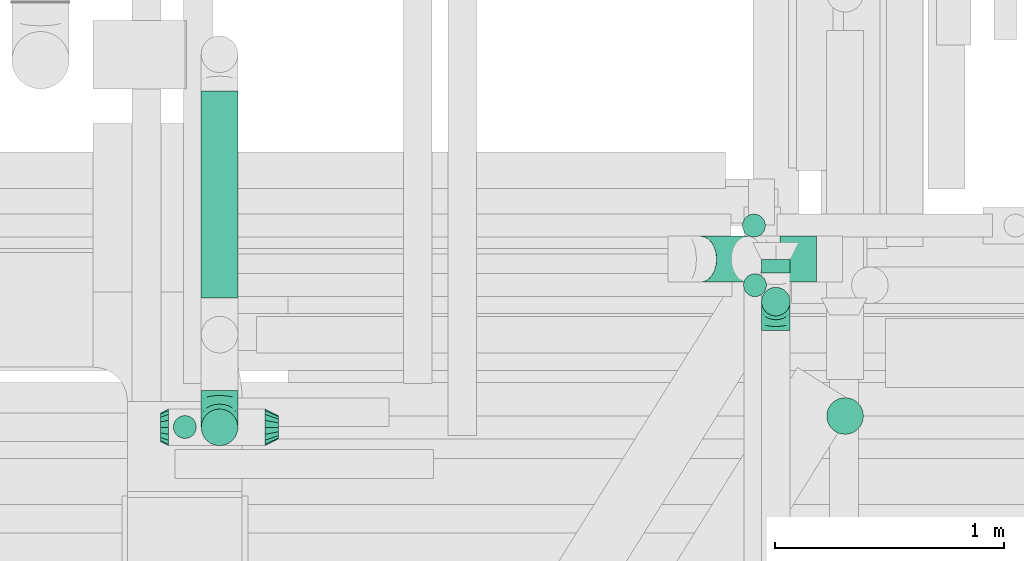
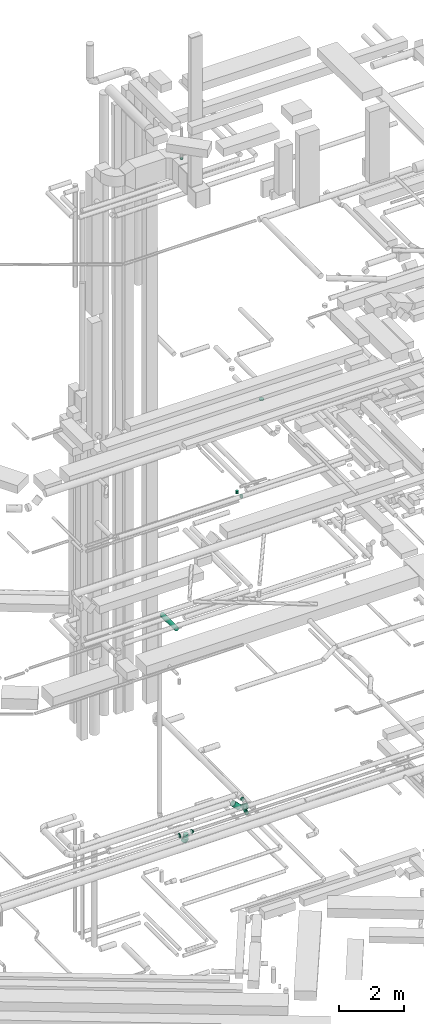
# One storey, part 100 of 337: 8 flow segments, 6 flow fittings.
"""IFC2X3 building model written with IfcOpenShell, lengths in millimetres."""

import ifcopenshell
import ifcopenshell.guid

model = None  # the IFC model being written
_history = None  # IfcOwnerHistory: only IFC2X3 demands one
_inside = {}  # id of a spatial element -> (the spatial element, [elements in it])
_under = {}  # id of a project, library or spatial element -> (it, [spatial elements below it])
_declared = {}  # id of a project -> (the project, [libraries it declares])
_typed = {}  # id of a type object -> (the type object, [elements of that type])
_made_of = {}  # id of a material, layer set ... -> (it, [elements and type objects made of it])


def new_model(schema):
    """Start an empty IFC model of exactly this schema.

    Asked for "IFC4X3", IfcOpenShell would pick the latest addendum, in which some entities
    have other attributes; the version numbers below select the first issue.
    IFC2X3 requires an IfcOwnerHistory on every rooted entity: one is made here for all.
    """
    global model, _history
    if schema == "IFC4X3":
        model = ifcopenshell.file(schema_version=(4, 3, 0, 0))
    else:
        model = ifcopenshell.file(schema=schema)
    _inside.clear()
    _under.clear()
    _declared.clear()
    _typed.clear()
    _made_of.clear()
    _history = None
    if model.schema == "IFC2X3":
        org = make("IfcOrganization", Name="unknown")
        user = make(
            "IfcPersonAndOrganization",
            ThePerson=make("IfcPerson", FamilyName="unknown"),
            TheOrganization=org,
        )
        app = make(
            "IfcApplication",
            ApplicationDeveloper=org,
            Version="unknown",
            ApplicationFullName="unknown",
            ApplicationIdentifier="unknown",
        )
        _history = make(
            "IfcOwnerHistory",
            OwningUser=user,
            OwningApplication=app,
            ChangeAction="ADDED",
            CreationDate=0,
        )
    return model


def make(cls, **values):
    """One entity of the class cls with the attributes given. An attribute that is None is left unset."""
    return model.create_entity(
        cls, **{name: value for name, value in values.items() if value is not None}
    )


def entity(cls, *values):
    """Any entity or typed value of the class cls, its attributes in the order of the schema. None: left unset."""
    e = model.create_entity(cls)
    for i, value in enumerate(values):
        if value is not None:
            e[i] = value
    return e


def rooted(cls, **values):
    """An entity with a GlobalId (a new one), such as an element, a storey or a relation."""
    return make(cls, GlobalId=ifcopenshell.guid.new(), OwnerHistory=_history, **values)


def si_unit(unit_type, name, prefix=None):
    """IfcSIUnit, for example si_unit("LENGTHUNIT", "METRE", prefix="MILLI")."""
    return make("IfcSIUnit", UnitType=unit_type, Prefix=prefix, Name=name)


def converted_unit(unit_type, name, factor, base, dimensions=None, offset=None):
    """IfcConversionBasedUnit, such as the inch: factor (a typed value) times the base unit."""
    return make(
        "IfcConversionBasedUnit"
        if offset is None
        else "IfcConversionBasedUnitWithOffset",
        ConversionOffset=offset,
        Dimensions=None
        if dimensions is None
        else entity("IfcDimensionalExponents", *dimensions),
        UnitType=unit_type,
        Name=name,
        ConversionFactor=make(
            "IfcMeasureWithUnit", ValueComponent=factor, UnitComponent=base
        ),
    )


def derived_unit(unit_type, elements):
    """IfcDerivedUnit: a product of units, each with its exponent."""
    return make(
        "IfcDerivedUnit",
        Elements=[
            make("IfcDerivedUnitElement", Unit=unit, Exponent=power)
            for unit, power in elements
        ],
        UnitType=unit_type,
    )


def assignment(units):
    """IfcUnitAssignment: the units of a project."""
    return None if units is None else make("IfcUnitAssignment", Units=units)


def point(xyz):
    """IfcCartesianPoint."""
    return None if xyz is None else make("IfcCartesianPoint", Coordinates=xyz)


def direction(xyz):
    """IfcDirection."""
    return None if xyz is None else make("IfcDirection", DirectionRatios=xyz)


def frame(location, z_axis=None, x_axis=None):
    """IfcAxis2Placement3D, a coordinate frame: its origin and axes. An axis left out is left unset."""
    return make(
        "IfcAxis2Placement3D",
        Location=point(location),
        Axis=direction(z_axis),
        RefDirection=direction(x_axis),
    )


def frame_2d(location, x_axis=None):
    """IfcAxis2Placement2D, a coordinate frame in the plane: its origin and x axis."""
    return make(
        "IfcAxis2Placement2D", Location=point(location), RefDirection=direction(x_axis)
    )


def origin():
    """The frame at (0, 0, 0) with its axes left unset."""
    return frame((0.0, 0.0, 0.0))


def origin_2d_with_axis():
    """The frame at (0, 0) in the plane with the x axis (1, 0) written out."""
    return frame_2d((0.0, 0.0), x_axis=(1.0, 0.0))


def place(relative_to, where):
    """IfcLocalPlacement: puts the frame where relative to a parent placement (None: the world)."""
    return make(
        "IfcLocalPlacement", PlacementRelTo=relative_to, RelativePlacement=where
    )


def context(
    kind, dimensions, precision=None, world=None, true_north=None, identifier=None
):
    """IfcGeometricRepresentationContext, for example the 3D "Model" context."""
    return make(
        "IfcGeometricRepresentationContext",
        ContextIdentifier=identifier,
        ContextType=kind,
        CoordinateSpaceDimension=dimensions,
        Precision=precision,
        WorldCoordinateSystem=world,
        TrueNorth=true_north,
    )


def subcontext(parent, identifier, kind, view, scale=None):
    """IfcGeometricRepresentationSubContext, for example "Body" below "Model"."""
    return make(
        "IfcGeometricRepresentationSubContext",
        ContextIdentifier=identifier,
        ContextType=kind,
        ParentContext=parent,
        TargetScale=scale,
        TargetView=view,
    )


def project(units=None, contexts=None):
    """IfcProject with its units and contexts."""
    return rooted(
        "IfcProject",
        Name="project",
        RepresentationContexts=contexts,
        UnitsInContext=assignment(units),
    )


def spatial(cls, under=None, at=None, **own):
    """A site, building, storey or space (cls), placed at a placement, below another one or the project."""
    s = rooted(cls, ObjectPlacement=at, **own)
    if under is not None:
        _under.setdefault(under.id(), (under, []))[1].append(s)
    return s


def profile(cls, at=None, kind="AREA", **sizes):
    """A parametric profile (cls). Its sizes go by their IFC names, for example OverallWidth=200.0."""
    return make(cls, ProfileType=kind, Position=at, **sizes)


def circle(**sizes):
    """IfcCircleProfileDef."""
    return profile("IfcCircleProfileDef", **sizes)


def extrude(swept, where, along, depth):
    """IfcExtrudedAreaSolid: the profile swept, set in the frame where, extruded along a direction by depth."""
    return make(
        "IfcExtrudedAreaSolid",
        SweptArea=swept,
        Position=where,
        ExtrudedDirection=direction(along),
        Depth=depth,
    )


def faces_of(points, faces, orient=None, outer=None):
    """IfcFace entities. A face is a list of loops; a loop is a list of indices into points, from 0.

    orient and outer hold one flag for each loop. By default every Orientation is true, the
    first loop of a face is its IfcFaceOuterBound and the others are IfcFaceBound.
    """
    made = []
    for i, loops in enumerate(faces):
        bounds = []
        for j, loop in enumerate(loops):
            is_outer = j == 0 if outer is None else outer[i][j]
            bounds.append(
                make(
                    "IfcFaceOuterBound" if is_outer else "IfcFaceBound",
                    Bound=make("IfcPolyLoop", Polygon=[points[k] for k in loop]),
                    Orientation=True if orient is None else orient[i][j],
                )
            )
        made.append(make("IfcFace", Bounds=bounds))
    return made


def faceted_brep(points, faces, orient=None, outer=None, voids=None):
    """IfcFacetedBrep: a solid bounded by flat faces; with voids (closed shells), ...WithVoids."""
    shared = [point(p) for p in points]
    hull = make("IfcClosedShell", CfsFaces=faces_of(shared, faces, orient, outer))
    if voids is None:
        return make("IfcFacetedBrep", Outer=hull)
    return make(
        "IfcFacetedBrepWithVoids",
        Outer=hull,
        Voids=[
            make(cls, CfsFaces=faces_of(shared, fs, o, b)) for cls, fs, o, b in voids
        ],
    )


def shape(context_of_items, identifier, shape_type, items):
    """IfcShapeRepresentation: the items that make up one representation, for example the "Body"."""
    return make(
        "IfcShapeRepresentation",
        ContextOfItems=context_of_items,
        RepresentationIdentifier=identifier,
        RepresentationType=shape_type,
        Items=items,
    )


def source(mapping_origin, context_of_items, identifier, shape_type, items):
    """IfcRepresentationMap: a shape defined once, which mapped items show again and again."""
    return make(
        "IfcRepresentationMap",
        MappingOrigin=mapping_origin,
        MappedRepresentation=shape(context_of_items, identifier, shape_type, items),
    )


def transform(
    local_origin,
    x_axis=None,
    y_axis=None,
    z_axis=None,
    scale=None,
    scale2=None,
    scale3=None,
    uniform=True,
):
    """IfcCartesianTransformationOperator3D, or its non-uniform kind. x_axis, y_axis, z_axis: its Axis1, 2, 3."""
    if uniform:
        return make(
            "IfcCartesianTransformationOperator3D",
            Axis1=direction(x_axis),
            Axis2=direction(y_axis),
            LocalOrigin=point(local_origin),
            Scale=scale,
            Axis3=direction(z_axis),
        )
    return make(
        "IfcCartesianTransformationOperator3DnonUniform",
        Axis1=direction(x_axis),
        Axis2=direction(y_axis),
        LocalOrigin=point(local_origin),
        Scale=scale,
        Axis3=direction(z_axis),
        Scale2=scale2,
        Scale3=scale3,
    )


def mapped(mapping_source, mapping_target):
    """IfcMappedItem: shows the shape of a source again, moved by a transform."""
    return make(
        "IfcMappedItem", MappingSource=mapping_source, MappingTarget=mapping_target
    )


def material(Name=None, Category=None):
    """IfcMaterial."""
    return make("IfcMaterial", Name=Name, Category=Category)


def made_of(thing, what):
    """Note that an element or type object is made of a material, layer set ...; save() writes the relation."""
    if what is not None:
        _made_of.setdefault(what.id(), (what, []))[1].append(thing)
    return thing


def type_object(cls, material=None, **own):
    """A type object (cls), such as IfcWallType, which elements share."""
    return made_of(rooted(cls, **own), material)


def type_shapes(of_type, sources):
    """Give a type object the sources (RepresentationMaps) that its elements show as mapped items."""
    of_type.RepresentationMaps = sources


def element(
    cls,
    number,
    at=None,
    inside=None,
    cuts=None,
    type_object=None,
    material=None,
    context=None,
    identifier="Body",
    shape_type=None,
    held_by="IfcProductDefinitionShape",
    body=None,
    shapes=None,
    **own,
):
    """One element of the class cls, such as IfcWall. Its Tag is "e" and its number.

    at: its placement. inside: the storey or other place that contains it. cuts: it is an
    opening in that element (IfcRelVoidsElement). A single representation is given by context,
    identifier, shape_type and body (its items); several are given by shapes. held_by: the class
    of the entity that holds the representations. save() writes the other relations.
    """
    e = rooted(cls, Tag="e%d" % number, ObjectPlacement=at, **own)
    if body is not None:
        shapes = [shape(context, identifier, shape_type, body)]
    if shapes is not None:
        e.Representation = make(held_by, Representations=shapes)
    if inside is not None:
        _inside.setdefault(inside.id(), (inside, []))[1].append(e)
    if cuts is not None:
        rooted(
            "IfcRelVoidsElement", RelatingBuildingElement=cuts, RelatedOpeningElement=e
        )
    if type_object is not None:
        _typed.setdefault(type_object.id(), (type_object, []))[1].append(e)
    return made_of(e, material)


def aggregate(whole, parts):
    """IfcRelAggregates: a whole, such as a stair, and the parts it consists of."""
    return rooted("IfcRelAggregates", RelatingObject=whole, RelatedObjects=parts)


def save(model, path):
    """Write the relations noted so far, then the file.

    IfcRelAggregates (storeys below a building ...), IfcRelContainedInSpatialStructure (elements
    in a storey), IfcRelDefinesByType, IfcRelAssociatesMaterial and IfcRelDeclares: one each for
    every whole, place, type object, material and project.
    """
    for whole, parts in _under.values():
        aggregate(whole, parts)
    for where, things in _inside.values():
        rooted(
            "IfcRelContainedInSpatialStructure",
            RelatedElements=things,
            RelatingStructure=where,
        )
    for kind, things in _typed.values():
        rooted("IfcRelDefinesByType", RelatedObjects=things, RelatingType=kind)
    for what, things in _made_of.values():
        rooted("IfcRelAssociatesMaterial", RelatedObjects=things, RelatingMaterial=what)
    for by, libraries in _declared.values():
        rooted("IfcRelDeclares", RelatingContext=by, RelatedDefinitions=libraries)
    model.write(path)


model = new_model("IFC2X3")

# Units and contexts
model_context = context("Model", 3, precision=0.01, world=origin(), true_north=direction((6.12303176911189e-17, 1.0)))
body_context = subcontext(model_context, "Body", "Model", "MODEL_VIEW")
ifc_project = project(units=[si_unit("LENGTHUNIT", "METRE", prefix="MILLI"), si_unit("AREAUNIT", "SQUARE_METRE"), si_unit("VOLUMEUNIT", "CUBIC_METRE"), converted_unit("PLANEANGLEUNIT", "DEGREE", entity("IfcRatioMeasure", 0.0174532925199433), si_unit("PLANEANGLEUNIT", "RADIAN"), dimensions=[0, 0, 0, 0, 0, 0, 0]), si_unit("MASSUNIT", "GRAM", prefix="KILO"), derived_unit("MASSDENSITYUNIT", [(si_unit("MASSUNIT", "GRAM", prefix="KILO"), 1), (si_unit("LENGTHUNIT", "METRE"), -3)]), derived_unit("MOMENTOFINERTIAUNIT", [(si_unit("LENGTHUNIT", "METRE"), 4)]), si_unit("TIMEUNIT", "SECOND"), si_unit("FREQUENCYUNIT", "HERTZ"), si_unit("THERMODYNAMICTEMPERATUREUNIT", "DEGREE_CELSIUS"), derived_unit("THERMALTRANSMITTANCEUNIT", [(si_unit("MASSUNIT", "GRAM", prefix="KILO"), 1), (si_unit("THERMODYNAMICTEMPERATUREUNIT", "KELVIN"), -1), (si_unit("TIMEUNIT", "SECOND"), -3)]), derived_unit("VOLUMETRICFLOWRATEUNIT", [(si_unit("LENGTHUNIT", "METRE"), 3), (si_unit("TIMEUNIT", "SECOND"), -1)]), derived_unit("MASSFLOWRATEUNIT", [(si_unit("MASSUNIT", "GRAM", prefix="KILO"), 1), (si_unit("TIMEUNIT", "SECOND"), -1)]), derived_unit("ROTATIONALFREQUENCYUNIT", [(si_unit("TIMEUNIT", "SECOND"), -1)]), si_unit("ELECTRICCURRENTUNIT", "AMPERE"), si_unit("ELECTRICVOLTAGEUNIT", "VOLT"), si_unit("POWERUNIT", "WATT"), si_unit("FORCEUNIT", "NEWTON", prefix="KILO"), si_unit("ILLUMINANCEUNIT", "LUX"), si_unit("LUMINOUSFLUXUNIT", "LUMEN"), si_unit("LUMINOUSINTENSITYUNIT", "CANDELA"), derived_unit("USERDEFINED", [(si_unit("MASSUNIT", "GRAM", prefix="KILO"), -1), (si_unit("LENGTHUNIT", "METRE"), -2), (si_unit("TIMEUNIT", "SECOND"), 3), (si_unit("LUMINOUSFLUXUNIT", "LUMEN"), 1)]), derived_unit("LINEARVELOCITYUNIT", [(si_unit("LENGTHUNIT", "METRE"), 1), (si_unit("TIMEUNIT", "SECOND"), -1)]), si_unit("PRESSUREUNIT", "PASCAL"), derived_unit("USERDEFINED", [(si_unit("LENGTHUNIT", "METRE"), -2), (si_unit("MASSUNIT", "GRAM", prefix="KILO"), 1), (si_unit("TIMEUNIT", "SECOND"), -2)]), derived_unit("LINEARFORCEUNIT", [(si_unit("MASSUNIT", "GRAM", prefix="KILO"), 1), (si_unit("LENGTHUNIT", "METRE"), 1), (si_unit("TIMEUNIT", "SECOND"), -2), (si_unit("LENGTHUNIT", "METRE"), -1)]), derived_unit("PLANARFORCEUNIT", [(si_unit("MASSUNIT", "GRAM", prefix="KILO"), 1), (si_unit("LENGTHUNIT", "METRE"), 1), (si_unit("TIMEUNIT", "SECOND"), -2), (si_unit("LENGTHUNIT", "METRE"), -2)])], contexts=[model_context])

# Site, building, storey
site_placement = place(None, origin())
site = spatial("IfcSite", under=ifc_project, at=site_placement, CompositionType="ELEMENT")
building_placement = place(site_placement, origin())
building = spatial("IfcBuilding", under=site, at=building_placement, CompositionType="ELEMENT")
storey_placement = place(building_placement, origin())
storey = spatial("IfcBuildingStorey", under=building, at=storey_placement, CompositionType="ELEMENT", Elevation=0.0)

# Flow segments
duct_segment_type = type_object("IfcDuctSegmentType", PredefinedType="NOTDEFINED")
flow_segment_1_placement = place(storey_placement, frame((10443.31, 12874.35, 10918.4)))
element("IfcFlowSegment", 1, at=flow_segment_1_placement, inside=storey, type_object=duct_segment_type, context=body_context, shape_type="SweptSolid", body=[
    extrude(circle(Radius=80.0, at=origin_2d_with_axis()), frame((81.6, 0.0, 81.6), z_axis=(0.0, 1.0, 0.0), x_axis=(-1.0, 0.0, 0.0)), (0.0, 0.0, 1.0), 902.152225627248),
])
flow_segment_2_placement = place(storey_placement, frame((12966.97, 12941.75, 3235.9)))
element("IfcFlowSegment", 2, at=flow_segment_2_placement, inside=storey, type_object=duct_segment_type, context=body_context, shape_type="SweptSolid", body=[
    extrude(circle(Radius=100.0, at=origin_2d_with_axis()), frame((0.0, 101.6, 101.6), z_axis=(1.0, 0.0, 0.0), x_axis=(0.0, -1.0, 0.0)), (0.0, 0.0, 1.0), 159.657287525383),
])
flow_segment_3_placement = place(storey_placement, frame((12547.9, 12941.75, 3323.77)))
element("IfcFlowSegment", 3, at=flow_segment_3_placement, inside=storey, type_object=duct_segment_type, context=body_context, shape_type="SweptSolid", body=[
    extrude(circle(Radius=100.0, at=origin_2d_with_axis()), frame((72.31, 101.6, 277.65), z_axis=(0.70710678118654, 0.0, -0.707106781186555), x_axis=(0.0, -1.0, 0.0)), (0.0, 0.0, 1.0), 290.398448916071),
])
flow_segment_4_placement = place(storey_placement, frame((12802.08, 13138.4, 15100.0)))
element("IfcFlowSegment", 4, at=flow_segment_4_placement, inside=storey, type_object=duct_segment_type, context=body_context, shape_type="SweptSolid", body=[
    extrude(circle(Radius=50.0, at=origin_2d_with_axis()), frame((51.6, 51.6, 0.0), z_axis=(0.0, 0.0, 1.0), x_axis=(0.0, -1.0, 0.0)), (0.0, 0.0, 1.0), 100.000000000008),
])
flow_segment_5_placement = place(storey_placement, frame((13169.37, 12278.22, 18995.0)))
element("IfcFlowSegment", 5, at=flow_segment_5_placement, inside=storey, type_object=duct_segment_type, context=body_context, shape_type="SweptSolid", body=[
    extrude(circle(Radius=80.0, at=origin_2d_with_axis()), frame((81.6, 81.6, 0.0)), (0.0, 0.0, 1.0), 34.9999999999076),
])
flow_segment_6_placement = place(storey_placement, frame((12806.72, 12878.4, 15100.0)))
element("IfcFlowSegment", 6, at=flow_segment_6_placement, inside=storey, type_object=duct_segment_type, context=body_context, shape_type="SweptSolid", body=[
    extrude(circle(Radius=50.0, at=origin_2d_with_axis()), frame((51.6, 51.6, 0.0), z_axis=(0.0, 0.0, 1.0), x_axis=(0.0, 1.0, 0.0)), (0.0, 0.0, 1.0), 100.000000000021),
])
flow_segment_7_placement = place(storey_placement, frame((12885.07, 12983.38, 3595.9)))
element("IfcFlowSegment", 7, at=flow_segment_7_placement, inside=storey, type_object=duct_segment_type, context=body_context, shape_type="SweptSolid", body=[
    extrude(circle(Radius=62.5, at=origin_2d_with_axis()), frame((64.1, 0.0, 64.1), z_axis=(0.0, 1.0, 0.0), x_axis=(-1.0, 0.0, 0.0)), (0.0, 0.0, 1.0), 57.5000000000237),
])
flow_segment_8_placement = place(storey_placement, frame((12885.07, 12794.28, 3425.0)))
element("IfcFlowSegment", 8, at=flow_segment_8_placement, inside=storey, type_object=duct_segment_type, context=body_context, shape_type="SweptSolid", body=[
    extrude(circle(Radius=62.5, at=origin_2d_with_axis()), frame((64.1, 64.1, 0.0)), (0.0, 0.0, 1.0), 110.000000000016),
])

# Flow fittings
ifc_material = material()
duct_fitting_type_1 = type_object("IfcDuctFittingType", PredefinedType="NOTDEFINED", material=ifc_material)
shared_shape_1 = source(origin(), body_context, "Body", "Brep", [
    faceted_brep([(-160.0, 0.0, -80.0), (-160.0, -20.71, -77.27), (-160.0, -40.0, -69.28), (-160.0, -56.57, -56.57), (-160.0, -69.28, -40.0), (-160.0, -77.27, -20.71), (-160.0, -80.0, 0.0), (-160.0, -77.27, 20.71), (-160.0, -69.28, 40.0), (-160.0, -56.57, 56.57), (-160.0, -40.0, 69.28), (-160.0, -20.71, 77.27), (-160.0, 0.0, 80.0), (-160.0, 20.71, 77.27), (-160.0, 40.0, 69.28), (-160.0, 56.57, 56.57), (-160.0, 69.28, 40.0), (-160.0, 77.27, 20.71), (-160.0, 80.0, 0.0), (-160.0, 77.27, -20.71), (-160.0, 69.28, -40.0), (-160.0, 56.57, -56.57), (-160.0, 40.0, -69.28), (-160.0, 20.71, -77.27), (-122.68, 20.71, 77.27), (-127.85, 40.0, 69.28), (-117.13, 0.0, 80.0), (-132.29, 56.57, 56.57), (-137.83, 77.27, 20.71), (-138.56, 80.0, 0.0), (-135.69, 69.28, 40.0), (-135.69, 69.28, -40.0), (-132.29, 56.57, -56.57), (-137.83, 77.27, -20.71), (-122.68, 20.71, -77.27), (-117.13, 0.0, -80.0), (-127.85, 40.0, -69.28), (-111.58, -20.71, -77.27), (-106.41, -40.0, -69.28), (-101.97, -56.57, -56.57), (-98.56, -69.28, -40.0), (-96.42, -77.27, -20.71), (-95.69, -80.0, 0.0), (-96.42, -77.27, 20.71), (-98.56, -69.28, 40.0), (-101.97, -56.57, 56.57), (-106.41, -40.0, 69.28), (-111.58, -20.71, 77.27), (-58.03, 58.03, 77.27), (-72.15, 72.15, 69.28), (-42.87, 42.87, 80.0), (-84.28, 84.28, 56.57), (-93.59, 93.59, 40.0), (-99.44, 99.44, 20.71), (-101.44, 101.44, 0.0), (-99.44, 99.44, -20.71), (-93.59, 93.59, -40.0), (-84.28, 84.28, -56.57), (-58.03, 58.03, -77.27), (-42.87, 42.87, -80.0), (-72.15, 72.15, -69.28), (-27.71, 27.71, -77.27), (-13.59, 13.59, -69.28), (-1.46, 1.46, -56.57), (7.85, -7.85, -40.0), (13.7, -13.7, -20.71), (15.69, -15.69, 0.0), (13.7, -13.7, 20.71), (7.85, -7.85, 40.0), (-1.46, 1.46, 56.57), (-13.59, 13.59, 69.28), (-27.71, 27.71, 77.27), (-20.71, 122.68, 77.27), (-40.0, 127.85, 69.28), (0.0, 117.13, 80.0), (-56.57, 132.29, 56.57), (-69.28, 135.69, 40.0), (-77.27, 137.83, 20.71), (-80.0, 138.56, 0.0), (-77.27, 137.83, -20.71), (-69.28, 135.69, -40.0), (-56.57, 132.29, -56.57), (-20.71, 122.68, -77.27), (0.0, 117.13, -80.0), (-40.0, 127.85, -69.28), (20.71, 111.58, -77.27), (40.0, 106.41, -69.28), (56.57, 101.97, -56.57), (69.28, 98.56, -40.0), (77.27, 96.42, -20.71), (80.0, 95.69, 0.0), (77.27, 96.42, 20.71), (69.28, 98.56, 40.0), (56.57, 101.97, 56.57), (40.0, 106.41, 69.28), (20.71, 111.58, 77.27), (-20.71, 160.0, -77.27), (-40.0, 160.0, -69.28), (-56.57, 160.0, -56.57), (-69.28, 160.0, -40.0), (-77.27, 160.0, -20.71), (-80.0, 160.0, 0.0), (-77.27, 160.0, 20.71), (-69.28, 160.0, 40.0), (-56.57, 160.0, 56.57), (-40.0, 160.0, 69.28), (-20.71, 160.0, 77.27), (0.0, 160.0, 80.0), (20.71, 160.0, 77.27), (40.0, 160.0, 69.28), (56.57, 160.0, 56.57), (69.28, 160.0, 40.0), (77.27, 160.0, 20.71), (80.0, 160.0, 0.0), (77.27, 160.0, -20.71), (69.28, 160.0, -40.0), (56.57, 160.0, -56.57), (40.0, 160.0, -69.28), (20.71, 160.0, -77.27), (0.0, 160.0, -80.0)], [[[0, 1, 2, 3, 4, 5, 6, 7, 8, 9, 10, 11, 12, 13, 14, 15, 16, 17, 18, 19, 20, 21, 22, 23]], [[24, 25, 14, 13]], [[26, 24, 13, 12]], [[14, 25, 27, 15]], [[28, 29, 18, 17]], [[30, 28, 17, 16]], [[15, 27, 30, 16]], [[20, 31, 32, 21]], [[33, 31, 20, 19]], [[18, 29, 33, 19]], [[34, 35, 0, 23]], [[36, 34, 23, 22]], [[32, 36, 22, 21]], [[1, 0, 35, 37]], [[2, 1, 37, 38]], [[3, 2, 38, 39]], [[5, 4, 40, 41]], [[6, 5, 41, 42]], [[39, 40, 4, 3]], [[6, 42, 43, 7]], [[7, 43, 44, 8]], [[8, 44, 45, 9]], [[9, 45, 46, 10]], [[10, 46, 47, 11]], [[26, 12, 11, 47]], [[48, 49, 25, 24]], [[50, 48, 24, 26]], [[27, 25, 49, 51]], [[52, 53, 28, 30]], [[51, 52, 30, 27]], [[29, 28, 53, 54]], [[55, 56, 31, 33]], [[54, 55, 33, 29]], [[32, 31, 56, 57]], [[58, 59, 35, 34]], [[60, 58, 34, 36]], [[57, 60, 36, 32]], [[37, 35, 59, 61]], [[38, 37, 61, 62]], [[39, 38, 62, 63]], [[41, 40, 64, 65]], [[42, 41, 65, 66]], [[63, 64, 40, 39]], [[43, 42, 66, 67]], [[44, 43, 67, 68]], [[68, 69, 45, 44]], [[46, 45, 69, 70]], [[47, 46, 70, 71]], [[26, 47, 71, 50]], [[72, 73, 49, 48]], [[74, 72, 48, 50]], [[51, 49, 73, 75]], [[76, 77, 53, 52]], [[75, 76, 52, 51]], [[54, 53, 77, 78]], [[79, 80, 56, 55]], [[78, 79, 55, 54]], [[57, 56, 80, 81]], [[82, 83, 59, 58]], [[84, 82, 58, 60]], [[81, 84, 60, 57]], [[61, 59, 83, 85]], [[62, 61, 85, 86]], [[63, 62, 86, 87]], [[65, 64, 88, 89]], [[66, 65, 89, 90]], [[87, 88, 64, 63]], [[67, 66, 90, 91]], [[68, 67, 91, 92]], [[92, 93, 69, 68]], [[70, 69, 93, 94]], [[71, 70, 94, 95]], [[50, 71, 95, 74]], [[96, 97, 98, 99, 100, 101, 102, 103, 104, 105, 106, 107, 108, 109, 110, 111, 112, 113, 114, 115, 116, 117, 118, 119]], [[72, 74, 107, 106]], [[73, 72, 106, 105]], [[75, 73, 105, 104]], [[77, 76, 103, 102]], [[78, 77, 102, 101]], [[75, 104, 103, 76]], [[78, 101, 100, 79]], [[79, 100, 99, 80]], [[80, 99, 98, 81]], [[84, 97, 96, 82]], [[82, 96, 119, 83]], [[84, 81, 98, 97]], [[118, 117, 86, 85]], [[119, 118, 85, 83]], [[116, 87, 86, 117]], [[88, 115, 114, 89]], [[89, 114, 113, 90]], [[115, 88, 87, 116]], [[112, 111, 92, 91]], [[113, 112, 91, 90]], [[111, 110, 93, 92]], [[95, 94, 109, 108]], [[74, 95, 108, 107]], [[110, 109, 94, 93]]]),
])
type_shapes(duct_fitting_type_1, [shared_shape_1])
flow_fitting_1_placement = place(storey_placement, frame((10524.9, 12310.36, 3320.0), z_axis=(-1.0, 0.0, 0.0), x_axis=(0.0, -1.0, 0.0)))
element("IfcFlowFitting", 9, at=flow_fitting_1_placement, inside=storey, type_object=duct_fitting_type_1, material=ifc_material, context=body_context, shape_type="MappedRepresentation", body=[
    mapped(shared_shape_1, transform((0.0, 0.0, 0.0), scale=1.0)),
])
duct_fitting_type_2 = type_object("IfcDuctFittingType", PredefinedType="NOTDEFINED", material=ifc_material)
shared_shape_2 = source(origin(), body_context, "Body", "Brep", [
    faceted_brep([(-125.0, 0.0, -62.5), (-125.0, -16.18, -60.37), (-125.0, -31.25, -54.13), (-125.0, -44.19, -44.19), (-125.0, -54.13, -31.25), (-125.0, -60.37, -16.18), (-125.0, -62.5, 0.0), (-125.0, -60.37, 16.18), (-125.0, -54.13, 31.25), (-125.0, -44.19, 44.19), (-125.0, -31.25, 54.13), (-125.0, -16.18, 60.37), (-125.0, 0.0, 62.5), (-125.0, 16.18, 60.37), (-125.0, 31.25, 54.13), (-125.0, 44.19, 44.19), (-125.0, 54.13, 31.25), (-125.0, 60.37, 16.18), (-125.0, 62.5, 0.0), (-125.0, 60.37, -16.18), (-125.0, 54.13, -31.25), (-125.0, 44.19, -44.19), (-125.0, 31.25, -54.13), (-125.0, 16.18, -60.37), (-95.84, 16.18, 60.37), (-99.88, 31.25, 54.13), (-91.51, 0.0, 62.5), (-103.35, 44.19, 44.19), (-107.68, 60.37, 16.18), (-108.25, 62.5, 0.0), (-106.01, 54.13, 31.25), (-106.01, 54.13, -31.25), (-103.35, 44.19, -44.19), (-107.68, 60.37, -16.18), (-95.84, 16.18, -60.37), (-91.51, 0.0, -62.5), (-99.88, 31.25, -54.13), (-87.17, -16.18, -60.37), (-83.13, -31.25, -54.13), (-79.66, -44.19, -44.19), (-77.0, -54.13, -31.25), (-75.33, -60.37, -16.18), (-74.76, -62.5, 0.0), (-75.33, -60.37, 16.18), (-77.0, -54.13, 31.25), (-79.66, -44.19, 44.19), (-83.13, -31.25, 54.13), (-87.17, -16.18, 60.37), (-45.34, 45.34, 60.37), (-56.37, 56.37, 54.13), (-33.49, 33.49, 62.5), (-65.85, 65.85, 44.19), (-73.12, 73.12, 31.25), (-77.69, 77.69, 16.18), (-79.25, 79.25, 0.0), (-77.69, 77.69, -16.18), (-73.12, 73.12, -31.25), (-65.85, 65.85, -44.19), (-45.34, 45.34, -60.37), (-33.49, 33.49, -62.5), (-56.37, 56.37, -54.13), (-21.65, 21.65, -60.37), (-10.62, 10.62, -54.13), (-1.14, 1.14, -44.19), (6.13, -6.13, -31.25), (10.7, -10.7, -16.18), (12.26, -12.26, 0.0), (10.7, -10.7, 16.18), (6.13, -6.13, 31.25), (-1.14, 1.14, 44.19), (-10.62, 10.62, 54.13), (-21.65, 21.65, 60.37), (-16.18, 95.84, 60.37), (-31.25, 99.88, 54.13), (0.0, 91.51, 62.5), (-44.19, 103.35, 44.19), (-54.13, 106.01, 31.25), (-60.37, 107.68, 16.18), (-62.5, 108.25, 0.0), (-60.37, 107.68, -16.18), (-54.13, 106.01, -31.25), (-44.19, 103.35, -44.19), (-16.18, 95.84, -60.37), (0.0, 91.51, -62.5), (-31.25, 99.88, -54.13), (16.18, 87.17, -60.37), (31.25, 83.13, -54.13), (44.19, 79.66, -44.19), (54.13, 77.0, -31.25), (60.37, 75.33, -16.18), (62.5, 74.76, 0.0), (60.37, 75.33, 16.18), (54.13, 77.0, 31.25), (44.19, 79.66, 44.19), (31.25, 83.13, 54.13), (16.18, 87.17, 60.37), (-16.18, 125.0, -60.37), (-31.25, 125.0, -54.13), (-44.19, 125.0, -44.19), (-54.13, 125.0, -31.25), (-60.37, 125.0, -16.18), (-62.5, 125.0, 0.0), (-60.37, 125.0, 16.18), (-54.13, 125.0, 31.25), (-44.19, 125.0, 44.19), (-31.25, 125.0, 54.13), (-16.18, 125.0, 60.37), (0.0, 125.0, 62.5), (16.18, 125.0, 60.37), (31.25, 125.0, 54.13), (44.19, 125.0, 44.19), (54.13, 125.0, 31.25), (60.37, 125.0, 16.18), (62.5, 125.0, 0.0), (60.37, 125.0, -16.18), (54.13, 125.0, -31.25), (44.19, 125.0, -44.19), (31.25, 125.0, -54.13), (16.18, 125.0, -60.37), (0.0, 125.0, -62.5)], [[[0, 1, 2, 3, 4, 5, 6, 7, 8, 9, 10, 11, 12, 13, 14, 15, 16, 17, 18, 19, 20, 21, 22, 23]], [[24, 25, 14, 13]], [[26, 24, 13, 12]], [[14, 25, 27, 15]], [[28, 29, 18, 17]], [[30, 28, 17, 16]], [[15, 27, 30, 16]], [[20, 31, 32, 21]], [[33, 31, 20, 19]], [[18, 29, 33, 19]], [[34, 35, 0, 23]], [[36, 34, 23, 22]], [[21, 32, 36, 22]], [[1, 0, 35, 37]], [[2, 1, 37, 38]], [[38, 39, 3, 2]], [[5, 4, 40, 41]], [[6, 5, 41, 42]], [[39, 40, 4, 3]], [[6, 42, 43, 7]], [[7, 43, 44, 8]], [[45, 9, 8, 44]], [[9, 45, 46, 10]], [[10, 46, 47, 11]], [[26, 12, 11, 47]], [[48, 49, 25, 24]], [[50, 48, 24, 26]], [[27, 25, 49, 51]], [[52, 53, 28, 30]], [[51, 52, 30, 27]], [[29, 28, 53, 54]], [[55, 56, 31, 33]], [[54, 55, 33, 29]], [[57, 32, 31, 56]], [[58, 59, 35, 34]], [[60, 58, 34, 36]], [[57, 60, 36, 32]], [[37, 35, 59, 61]], [[38, 37, 61, 62]], [[39, 38, 62, 63]], [[41, 40, 64, 65]], [[42, 41, 65, 66]], [[63, 64, 40, 39]], [[43, 42, 66, 67]], [[44, 43, 67, 68]], [[68, 69, 45, 44]], [[46, 45, 69, 70]], [[47, 46, 70, 71]], [[26, 47, 71, 50]], [[72, 73, 49, 48]], [[74, 72, 48, 50]], [[51, 49, 73, 75]], [[76, 77, 53, 52]], [[75, 76, 52, 51]], [[54, 53, 77, 78]], [[79, 80, 56, 55]], [[78, 79, 55, 54]], [[81, 57, 56, 80]], [[82, 83, 59, 58]], [[84, 82, 58, 60]], [[81, 84, 60, 57]], [[61, 59, 83, 85]], [[62, 61, 85, 86]], [[63, 62, 86, 87]], [[65, 64, 88, 89]], [[66, 65, 89, 90]], [[87, 88, 64, 63]], [[67, 66, 90, 91]], [[68, 67, 91, 92]], [[92, 93, 69, 68]], [[70, 69, 93, 94]], [[71, 70, 94, 95]], [[50, 71, 95, 74]], [[96, 97, 98, 99, 100, 101, 102, 103, 104, 105, 106, 107, 108, 109, 110, 111, 112, 113, 114, 115, 116, 117, 118, 119]], [[72, 74, 107, 106]], [[73, 72, 106, 105]], [[75, 73, 105, 104]], [[77, 76, 103, 102]], [[78, 77, 102, 101]], [[75, 104, 103, 76]], [[78, 101, 100, 79]], [[79, 100, 99, 80]], [[80, 99, 98, 81]], [[96, 119, 83, 82]], [[97, 96, 82, 84]], [[84, 81, 98, 97]], [[83, 119, 118, 85]], [[85, 118, 117, 86]], [[116, 87, 86, 117]], [[88, 115, 114, 89]], [[89, 114, 113, 90]], [[115, 88, 87, 116]], [[91, 90, 113, 112]], [[92, 91, 112, 111]], [[111, 110, 93, 92]], [[95, 94, 109, 108]], [[74, 95, 108, 107]], [[110, 109, 94, 93]]]),
])
type_shapes(duct_fitting_type_2, [shared_shape_2])
flow_fitting_2_placement = place(storey_placement, frame((12949.17, 12858.38, 3300.0), z_axis=(-1.0, 0.0, 0.0), x_axis=(0.0, 0.0, -1.0)))
element("IfcFlowFitting", 10, at=flow_fitting_2_placement, inside=storey, type_object=duct_fitting_type_2, material=ifc_material, context=body_context, shape_type="MappedRepresentation", body=[
    mapped(shared_shape_2, transform((0.0, 0.0, 0.0), scale=1.0)),
])
duct_fitting_type_3 = type_object("IfcDuctFittingType", PredefinedType="NOTDEFINED", material=ifc_material)
shared_shape_3 = source(origin(), body_context, "Body", "Brep", [
    faceted_brep([(60.0, -46.19, 19.13), (60.0, -48.1, 9.57), (60.0, -50.0, 0.0), (60.0, -48.1, -9.57), (60.0, -46.19, -19.13), (60.0, -40.77, -27.24), (60.0, -35.36, -35.36), (60.0, -27.24, -40.77), (60.0, -19.13, -46.19), (60.0, -9.57, -48.1), (60.0, 0.0, -50.0), (60.0, 9.57, -48.1), (60.0, 19.13, -46.19), (60.0, 27.24, -40.77), (60.0, 35.36, -35.36), (60.0, 40.77, -27.24), (60.0, 46.19, -19.13), (60.0, 48.1, -9.57), (60.0, 50.0, 0.0), (60.0, 48.1, 9.57), (60.0, 46.19, 19.13), (60.0, 40.77, 27.24), (60.0, 35.36, 35.36), (60.0, 27.24, 40.77), (60.0, 19.13, 46.19), (60.0, 9.57, 48.1), (60.0, 0.0, 50.0), (60.0, -9.57, 48.1), (60.0, -19.13, 46.19), (60.0, -27.24, 40.77), (60.0, -35.36, 35.36), (60.0, -40.77, 27.24), (0.0, -80.0, 0.0), (0.0, -77.16, 14.27), (0.0, -73.91, 30.61), (0.0, -65.24, 43.59), (0.0, -56.57, 56.57), (0.0, -43.59, 65.24), (0.0, -30.61, 73.91), (0.0, -15.31, 76.96), (0.0, 0.0, 80.0), (0.0, 14.27, 77.16), (0.0, 30.61, 73.91), (0.0, 43.59, 65.24), (0.0, 56.57, 56.57), (0.0, 65.24, 43.59), (0.0, 73.91, 30.61), (0.0, 76.96, 15.31), (0.0, 80.0, 0.0), (0.0, 77.16, -14.27), (0.0, 73.91, -30.61), (0.0, 65.24, -43.59), (0.0, 56.57, -56.57), (0.0, 43.59, -65.24), (0.0, 30.61, -73.91), (0.0, 15.31, -76.96), (0.0, 0.0, -80.0), (0.0, -14.27, -77.16), (0.0, -30.61, -73.91), (0.0, -43.59, -65.24), (0.0, -56.57, -56.57), (0.0, -65.24, -43.59), (0.0, -73.91, -30.61), (0.0, -76.96, -15.31)], [[[0, 1, 2, 3, 4, 5, 6, 7, 8, 9, 10, 11, 12, 13, 14, 15, 16, 17, 18, 19, 20, 21, 22, 23, 24, 25, 26, 27, 28, 29, 30, 31]], [[32, 33, 34, 35, 36, 37, 38, 39, 40, 41, 42, 43, 44, 45, 46, 47, 48, 49, 50, 51, 52, 53, 54, 55, 56, 57, 58, 59, 60, 61, 62, 63]], [[42, 41, 40, 26, 25, 24]], [[43, 42, 24, 23, 22, 44]], [[20, 46, 45, 44, 22, 21]], [[18, 48, 47, 46, 20, 19]], [[34, 33, 32, 2, 1, 0]], [[35, 34, 0, 31, 30, 36]], [[28, 38, 37, 36, 30, 29]], [[26, 40, 39, 38, 28, 27]], [[58, 57, 56, 10, 9, 8]], [[59, 58, 8, 7, 6, 60]], [[4, 62, 61, 60, 6, 5]], [[2, 32, 63, 62, 4, 3]], [[50, 49, 48, 18, 17, 16]], [[51, 50, 16, 15, 14, 52]], [[12, 54, 53, 52, 14, 13]], [[10, 56, 55, 54, 12, 11]]]),
])
type_shapes(duct_fitting_type_3, [shared_shape_3])
flow_fitting_3_placement = place(storey_placement, frame((10722.78, 12310.36, 3650.0)))
element("IfcFlowFitting", 11, at=flow_fitting_3_placement, inside=storey, type_object=duct_fitting_type_3, material=ifc_material, context=body_context, shape_type="MappedRepresentation", body=[
    mapped(shared_shape_3, transform((0.0, 0.0, 0.0), scale=1.0)),
])
duct_fitting_type_4 = type_object("IfcDuctFittingType", PredefinedType="NOTDEFINED", material=ifc_material)
shared_shape_4 = source(origin(), body_context, "Body", "Brep", [
    faceted_brep([(35.0, 0.0, -80.0), (35.0, 12.81, -77.45), (35.0, 30.61, -73.91), (35.0, 43.59, -65.24), (35.0, 56.57, -56.57), (35.0, 65.24, -43.59), (35.0, 73.91, -30.61), (35.0, 76.96, -15.31), (35.0, 80.0, 0.0), (35.0, 77.45, 12.81), (35.0, 73.91, 30.61), (35.0, 65.24, 43.59), (35.0, 56.57, 56.57), (35.0, 43.59, 65.24), (35.0, 30.61, 73.91), (35.0, 15.31, 76.96), (35.0, 0.0, 80.0), (35.0, -12.81, 77.45), (35.0, -30.61, 73.91), (35.0, -43.59, 65.24), (35.0, -56.57, 56.57), (35.0, -65.24, 43.59), (35.0, -73.91, 30.61), (35.0, -76.96, 15.31), (35.0, -80.0, 0.0), (35.0, -77.45, -12.81), (35.0, -73.91, -30.61), (35.0, -65.24, -43.59), (35.0, -56.57, -56.57), (35.0, -43.59, -65.24), (35.0, -30.61, -73.91), (35.0, -15.31, -76.96), (0.0, -23.92, -57.74), (0.0, -34.06, -50.97), (0.0, -44.19, -44.19), (0.0, -50.97, -34.06), (0.0, -57.74, -23.92), (0.0, -60.12, -11.96), (0.0, -62.5, 0.0), (0.0, -60.12, 11.96), (0.0, -57.74, 23.92), (0.0, -50.97, 34.06), (0.0, -44.19, 44.19), (0.0, -34.06, 50.97), (0.0, -23.92, 57.74), (0.0, -11.96, 60.12), (0.0, 0.0, 62.5), (0.0, 11.96, 60.12), (0.0, 23.92, 57.74), (0.0, 34.06, 50.97), (0.0, 44.19, 44.19), (0.0, 50.97, 34.06), (0.0, 57.74, 23.92), (0.0, 60.12, 11.96), (0.0, 62.5, 0.0), (0.0, 60.12, -11.96), (0.0, 57.74, -23.92), (0.0, 50.97, -34.06), (0.0, 44.19, -44.19), (0.0, 34.06, -50.97), (0.0, 23.92, -57.74), (0.0, 11.96, -60.12), (0.0, 0.0, -62.5), (0.0, -11.96, -60.12)], [[[0, 1, 2, 3, 4, 5, 6, 7, 8, 9, 10, 11, 12, 13, 14, 15, 16, 17, 18, 19, 20, 21, 22, 23, 24, 25, 26, 27, 28, 29, 30, 31]], [[32, 33, 34, 35, 36, 37, 38, 39, 40, 41, 42, 43, 44, 45, 46, 47, 48, 49, 50, 51, 52, 53, 54, 55, 56, 57, 58, 59, 60, 61, 62, 63]], [[10, 9, 8, 54, 53, 52]], [[11, 10, 52, 51, 50, 12]], [[48, 14, 13, 12, 50, 49]], [[46, 16, 15, 14, 48, 47]], [[18, 17, 16, 46, 45, 44]], [[19, 18, 44, 43, 42, 20]], [[40, 22, 21, 20, 42, 41]], [[38, 24, 23, 22, 40, 39]], [[26, 25, 24, 38, 37, 36]], [[27, 26, 36, 35, 34, 28]], [[32, 30, 29, 28, 34, 33]], [[62, 0, 31, 30, 32, 63]], [[2, 1, 0, 62, 61, 60]], [[3, 2, 60, 59, 58, 4]], [[56, 6, 5, 4, 58, 57]], [[54, 8, 7, 6, 56, 55]]]),
])
type_shapes(duct_fitting_type_4, [shared_shape_4])
flow_fitting_4_placement = place(storey_placement, frame((10267.78, 12310.36, 3650.0)))
element("IfcFlowFitting", 12, at=flow_fitting_4_placement, inside=storey, type_object=duct_fitting_type_4, material=ifc_material, context=body_context, shape_type="MappedRepresentation", body=[
    mapped(shared_shape_4, transform((0.0, 0.0, 0.0), scale=1.0)),
])
duct_fitting_type_5 = type_object("IfcDuctFittingType", PredefinedType="NOTDEFINED", material=ifc_material)
shared_shape_5 = source(origin(), body_context, "Body", "Brep", [
    faceted_brep([(20.0, 0.0, -50.0), (20.0, 12.94, -48.3), (20.0, 25.0, -43.3), (20.0, 35.36, -35.36), (20.0, 43.3, -25.0), (20.0, 48.3, -12.94), (20.0, 50.0, 0.0), (20.0, 48.3, 12.94), (20.0, 43.3, 25.0), (20.0, 35.36, 35.36), (20.0, 25.0, 43.3), (20.0, 12.94, 48.3), (20.0, 0.0, 50.0), (20.0, -12.94, 48.3), (20.0, -25.0, 43.3), (20.0, -35.36, 35.36), (20.0, -43.3, 25.0), (20.0, -48.3, 12.94), (20.0, -50.0, 0.0), (20.0, -48.3, -12.94), (20.0, -43.3, -25.0), (20.0, -35.36, -35.36), (20.0, -25.0, -43.3), (20.0, -12.94, -48.3), (0.0, 0.0, 50.0), (-6.1, 0.0, 50.0), (-6.1, -12.94, 48.3), (0.0, -12.94, 48.3), (-6.1, -25.0, 43.3), (0.0, -25.0, 43.3), (0.0, -35.36, 35.36), (-6.1, -35.36, 35.36), (0.0, -43.3, 25.0), (-6.1, -43.3, 25.0), (-6.1, -48.3, 12.94), (0.0, -48.3, 12.94), (-6.1, -50.0, 0.0), (0.0, -50.0, 0.0), (-6.1, -48.3, -12.94), (0.0, -48.3, -12.94), (-6.1, -43.3, -25.0), (0.0, -43.3, -25.0), (0.0, -35.36, -35.36), (-6.1, -35.36, -35.36), (0.0, -25.0, -43.3), (-6.1, -25.0, -43.3), (-6.1, -12.94, -48.3), (0.0, -12.94, -48.3), (-6.1, 0.0, -50.0), (0.0, 0.0, -50.0), (-6.1, 12.94, -48.3), (0.0, 12.94, -48.3), (-6.1, 25.0, -43.3), (0.0, 25.0, -43.3), (0.0, 35.36, -35.36), (-6.1, 35.36, -35.36), (0.0, 43.3, -25.0), (-6.1, 43.3, -25.0), (-6.1, 48.3, -12.94), (0.0, 48.3, -12.94), (-6.1, 50.0, 0.0), (0.0, 50.0, 0.0), (-6.1, 48.3, 12.94), (0.0, 48.3, 12.94), (-6.1, 43.3, 25.0), (0.0, 43.3, 25.0), (0.0, 35.36, 35.36), (-6.1, 35.36, 35.36), (0.0, 25.0, 43.3), (-6.1, 25.0, 43.3), (-6.1, 12.94, 48.3), (0.0, 12.94, 48.3)], [[[0, 1, 2, 3, 4, 5, 6, 7, 8, 9, 10, 11, 12, 13, 14, 15, 16, 17, 18, 19, 20, 21, 22, 23]], [[13, 12, 24, 25, 26, 27]], [[14, 13, 27, 26, 28, 29]], [[30, 15, 14, 29, 28, 31]], [[17, 16, 32, 33, 34, 35]], [[18, 17, 35, 34, 36, 37]], [[32, 16, 15, 30, 31, 33]], [[19, 18, 37, 36, 38, 39]], [[20, 19, 39, 38, 40, 41]], [[42, 21, 20, 41, 40, 43]], [[23, 22, 44, 45, 46, 47]], [[0, 23, 47, 46, 48, 49]], [[44, 22, 21, 42, 43, 45]], [[1, 0, 49, 48, 50, 51]], [[2, 1, 51, 50, 52, 53]], [[54, 3, 2, 53, 52, 55]], [[5, 4, 56, 57, 58, 59]], [[6, 5, 59, 58, 60, 61]], [[56, 4, 3, 54, 55, 57]], [[7, 6, 61, 60, 62, 63]], [[8, 7, 63, 62, 64, 65]], [[66, 9, 8, 65, 64, 67]], [[11, 10, 68, 69, 70, 71]], [[12, 11, 71, 70, 25, 24]], [[68, 10, 9, 66, 67, 69]], [[46, 45, 43, 40, 38, 36, 34, 33, 31, 28, 26, 25, 70, 69, 67, 64, 62, 60, 58, 57, 55, 52, 50, 48]]]),
])
type_shapes(duct_fitting_type_5, [shared_shape_5])
flow_fitting_5_placement = place(storey_placement, frame((10373.64, 12311.85, 29100.0), z_axis=(0.0, -1.0, 0.0), x_axis=(0.0, 0.0, 1.0)))
element("IfcFlowFitting", 13, at=flow_fitting_5_placement, inside=storey, type_object=duct_fitting_type_5, material=ifc_material, context=body_context, shape_type="MappedRepresentation", body=[
    mapped(shared_shape_5, transform((0.0, 0.0, 0.0), scale=1.0)),
])
duct_fitting_type_6 = type_object("IfcDuctFittingType", PredefinedType="NOTDEFINED", material=ifc_material)
shared_shape_6 = source(origin(), body_context, "Body", "Brep", [
    faceted_brep([(20.0, 0.0, -80.0), (20.0, 20.71, -77.27), (20.0, 40.0, -69.28), (20.0, 56.57, -56.57), (20.0, 69.28, -40.0), (20.0, 77.27, -20.71), (20.0, 80.0, 0.0), (20.0, 77.27, 20.71), (20.0, 69.28, 40.0), (20.0, 56.57, 56.57), (20.0, 40.0, 69.28), (20.0, 20.71, 77.27), (20.0, 0.0, 80.0), (20.0, -20.71, 77.27), (20.0, -40.0, 69.28), (20.0, -56.57, 56.57), (20.0, -69.28, 40.0), (20.0, -77.27, 20.71), (20.0, -80.0, 0.0), (20.0, -77.27, -20.71), (20.0, -69.28, -40.0), (20.0, -56.57, -56.57), (20.0, -40.0, -69.28), (20.0, -20.71, -77.27), (0.0, 0.0, 80.0), (-73.9, 0.0, 80.0), (-73.9, -20.71, 77.27), (0.0, -20.71, 77.27), (-73.9, -40.0, 69.28), (0.0, -40.0, 69.28), (0.0, -56.57, 56.57), (-73.9, -56.57, 56.57), (0.0, -69.28, 40.0), (-73.9, -69.28, 40.0), (-73.9, -77.27, 20.71), (0.0, -77.27, 20.71), (-73.9, -80.0, 0.0), (0.0, -80.0, 0.0), (-73.9, -77.27, -20.71), (0.0, -77.27, -20.71), (-73.9, -69.28, -40.0), (0.0, -69.28, -40.0), (0.0, -56.57, -56.57), (-73.9, -56.57, -56.57), (0.0, -40.0, -69.28), (-73.9, -40.0, -69.28), (-73.9, -20.71, -77.27), (0.0, -20.71, -77.27), (-73.9, 0.0, -80.0), (0.0, 0.0, -80.0), (-73.9, 20.71, -77.27), (0.0, 20.71, -77.27), (-73.9, 40.0, -69.28), (0.0, 40.0, -69.28), (0.0, 56.57, -56.57), (-73.9, 56.57, -56.57), (0.0, 69.28, -40.0), (-73.9, 69.28, -40.0), (-73.9, 77.27, -20.71), (0.0, 77.27, -20.71), (-73.9, 80.0, 0.0), (0.0, 80.0, 0.0), (-73.9, 77.27, 20.71), (0.0, 77.27, 20.71), (-73.9, 69.28, 40.0), (0.0, 69.28, 40.0), (0.0, 56.57, 56.57), (-73.9, 56.57, 56.57), (0.0, 40.0, 69.28), (-73.9, 40.0, 69.28), (-73.9, 20.71, 77.27), (0.0, 20.71, 77.27)], [[[0, 1, 2, 3, 4, 5, 6, 7, 8, 9, 10, 11, 12, 13, 14, 15, 16, 17, 18, 19, 20, 21, 22, 23]], [[13, 12, 24, 25, 26, 27]], [[14, 13, 27, 26, 28, 29]], [[30, 15, 14, 29, 28, 31]], [[17, 16, 32, 33, 34, 35]], [[18, 17, 35, 34, 36, 37]], [[32, 16, 15, 30, 31, 33]], [[19, 18, 37, 36, 38, 39]], [[20, 19, 39, 38, 40, 41]], [[42, 21, 20, 41, 40, 43]], [[23, 22, 44, 45, 46, 47]], [[0, 23, 47, 46, 48, 49]], [[44, 22, 21, 42, 43, 45]], [[1, 0, 49, 48, 50, 51]], [[2, 1, 51, 50, 52, 53]], [[54, 3, 2, 53, 52, 55]], [[5, 4, 56, 57, 58, 59]], [[6, 5, 59, 58, 60, 61]], [[56, 4, 3, 54, 55, 57]], [[7, 6, 61, 60, 62, 63]], [[8, 7, 63, 62, 64, 65]], [[66, 9, 8, 65, 64, 67]], [[11, 10, 68, 69, 70, 71]], [[12, 11, 71, 70, 25, 24]], [[68, 10, 9, 66, 67, 69]], [[46, 45, 43, 40, 38, 36, 34, 33, 31, 28, 26, 25, 70, 69, 67, 64, 62, 60, 58, 57, 55, 52, 50, 48]]]),
])
type_shapes(duct_fitting_type_6, [shared_shape_6])
flow_fitting_6_placement = place(storey_placement, frame((10524.9, 12310.36, 3570.0), z_axis=(0.0, -1.0, 0.0), x_axis=(0.0, 0.0, -1.0)))
element("IfcFlowFitting", 14, at=flow_fitting_6_placement, inside=storey, type_object=duct_fitting_type_6, material=ifc_material, context=body_context, shape_type="MappedRepresentation", body=[
    mapped(shared_shape_6, transform((0.0, 0.0, 0.0), scale=1.0)),
])

save(model, "model.ifc")
